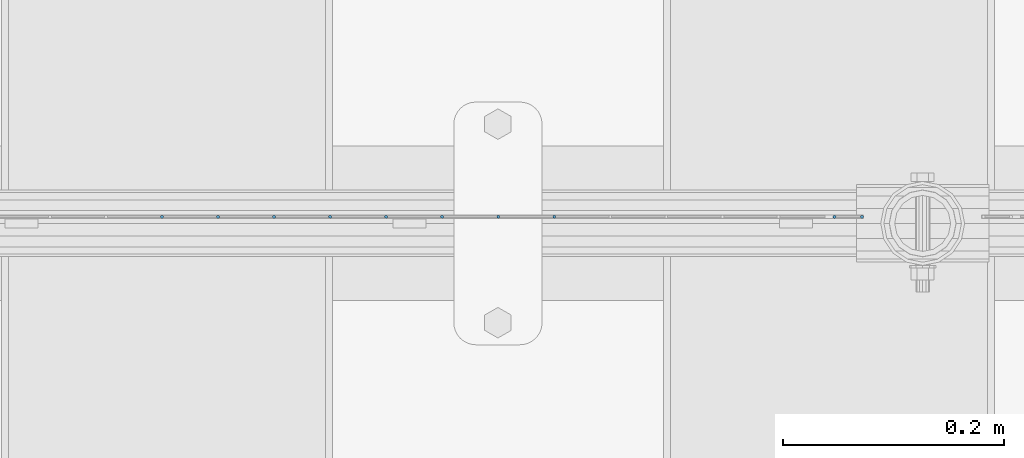
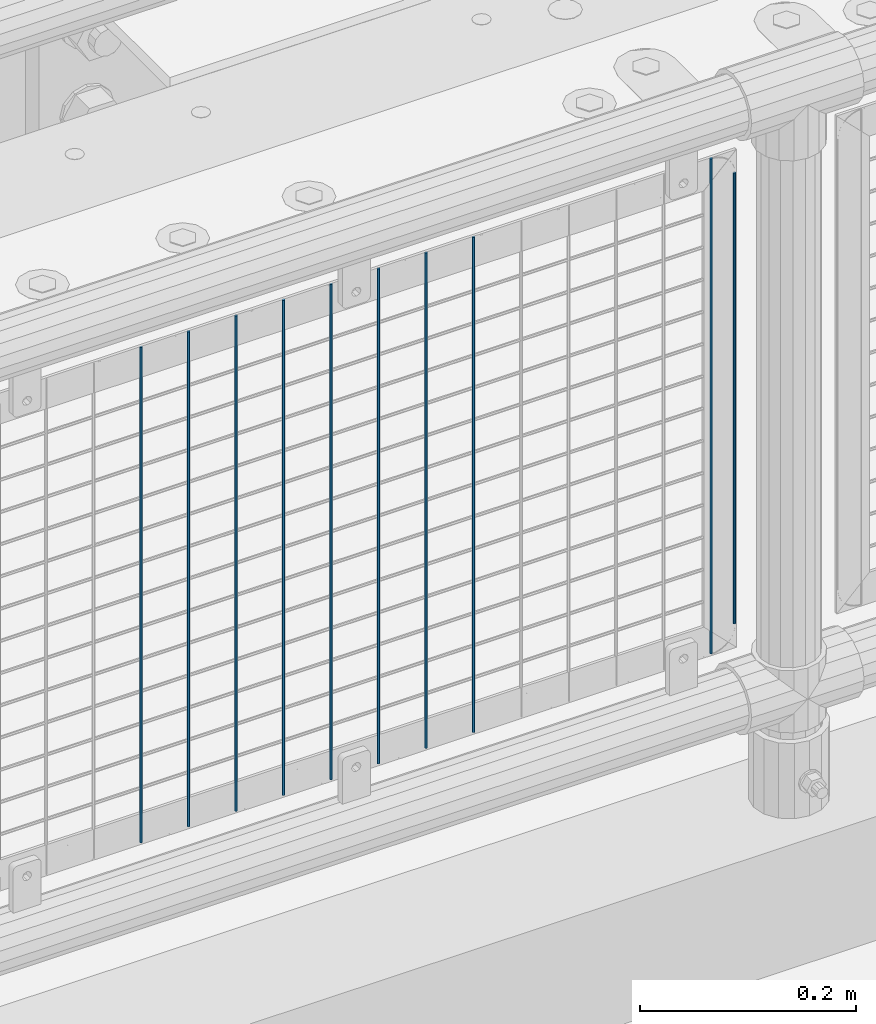
# One storey, part 96 of 270: 10 columns.
"""IFC2X3 building model written with IfcOpenShell, lengths in millimetres."""

from ifc_helpers import new_model, si_unit, frame, origin_with_axes, place, context, subcontext, project, spatial, faceted_brep, material, type_object, element, save


model = new_model("IFC2X3")

# Units and contexts
model_context = context("Model", 3, precision=1e-05, world=origin_with_axes())
body_context = subcontext(model_context, "Body", "Model", "MODEL_VIEW")
ifc_project = project(units=[si_unit("LENGTHUNIT", "METRE", prefix="MILLI"), si_unit("AREAUNIT", "SQUARE_METRE"), si_unit("VOLUMEUNIT", "CUBIC_METRE"), si_unit("MASSUNIT", "GRAM", prefix="KILO"), si_unit("TIMEUNIT", "SECOND"), si_unit("PLANEANGLEUNIT", "RADIAN"), si_unit("SOLIDANGLEUNIT", "STERADIAN"), si_unit("THERMODYNAMICTEMPERATUREUNIT", "DEGREE_CELSIUS"), si_unit("LUMINOUSINTENSITYUNIT", "LUMEN")], contexts=[model_context])

# Site, building, storey
site_placement = place(None, origin_with_axes())
site = spatial("IfcSite", under=ifc_project, at=site_placement, CompositionType="ELEMENT")
building_placement = place(site_placement, origin_with_axes())
building = spatial("IfcBuilding", under=site, at=building_placement, Name="Standard", CompositionType="ELEMENT")
storey_placement = place(building_placement, origin_with_axes())
storey = spatial("IfcBuildingStorey", under=building, at=storey_placement, Name="Undefined", CompositionType="ELEMENT", Elevation=0.0)

# Columns
ifc_material = material(Name="Misc_Undefined")
column_type = type_object("IfcColumnType", Name="D3", PredefinedType="NOTDEFINED")
for number, where, z_axis, x_axis in (
    (1, (13351.032, -16329.5, 353.02), (-1.0, 0.0, 0.0), (0.0, 0.0, 1.0)),
    (2, (13300.239, -16329.5, 353.02), (-1.0, 0.0, 0.0), (0.0, 0.0, 1.0)),
    (3, (13249.446, -16329.5, 353.02), (-1.0, 0.0, 0.0), (0.0, 0.0, 1.0)),
    (4, (13604.997, -16329.5, 353.02), (-1.0, 0.0, 0.0), (0.0, 0.0, 1.0)),
    (5, (13198.653, -16329.5, 353.02), (-1.0, 0.0, 0.0), (0.0, 0.0, 1.0)),
    (6, (13147.86, -16329.5, 353.02), (-1.0, 0.0, 0.0), (0.0, 0.0, 1.0)),
    (7, (13097.067, -16329.5, 353.02), (-1.0, 0.0, 0.0), (0.0, 0.0, 1.0)),
    (8, (13046.274, -16329.5, 353.02), (-1.0, 0.0, 0.0), (0.0, 0.0, 1.0)),
    (9, (12995.481, -16329.5, 353.02), (-1.0, 0.0, 0.0), (0.0, 0.0, 1.0)),
):
    element("IfcColumn", number, at=place(storey_placement, frame(where, z_axis=z_axis, x_axis=x_axis)), inside=storey, type_object=column_type, material=ifc_material, ObjectType="D3", context=body_context, shape_type="Brep", body=[
        faceted_brep([(0.0, -1.5, 0.0), (0.0, -0.75, -1.29903810567669), (560.0, -0.75, -1.29903810567703), (560.0, -1.5, 0.0), (0.0, 0.75, -1.29903810567669), (560.0, 0.75, -1.29903810567703), (0.0, 1.5, 0.0), (560.0, 1.5, 0.0), (0.0, 0.75, 1.29903810567669), (560.0, 0.75, 1.29903810567703), (0.0, -0.75, 1.29903810567669), (560.0, -0.75, 1.29903810567703)], [[[0, 1, 2, 3]], [[1, 4, 5, 2]], [[4, 6, 7, 5]], [[6, 8, 9, 7]], [[8, 10, 11, 9]], [[10, 0, 3, 11]], [[5, 7, 9, 11, 3, 2]], [[10, 8, 6, 4, 1, 0]]]),
    ])
column_placement = place(storey_placement, frame((13630.0, -16329.5, 378.02), z_axis=(-1.0, 0.0, 0.0), x_axis=(0.0, 0.0, 1.0)))
element("IfcColumn", 10, at=column_placement, inside=storey, type_object=column_type, material=ifc_material, ObjectType="D3", context=body_context, shape_type="Brep", body=[
    faceted_brep([(0.0, -1.5, 0.0), (0.0, -0.75, -1.29903810567669), (510.0, -0.75, -1.29903810567703), (510.0, -1.5, 0.0), (0.0, 0.75, -1.29903810567669), (510.0, 0.75, -1.29903810567703), (0.0, 1.5, 0.0), (510.0, 1.5, 0.0), (0.0, 0.75, 1.29903810567669), (510.0, 0.75, 1.29903810567703), (0.0, -0.75, 1.29903810567669), (510.0, -0.75, 1.29903810567703)], [[[0, 1, 2, 3]], [[1, 4, 5, 2]], [[4, 6, 7, 5]], [[6, 8, 9, 7]], [[8, 10, 11, 9]], [[10, 0, 3, 11]], [[5, 7, 9, 11, 3, 2]], [[10, 8, 6, 4, 1, 0]]]),
])

save(model, "model.ifc")
